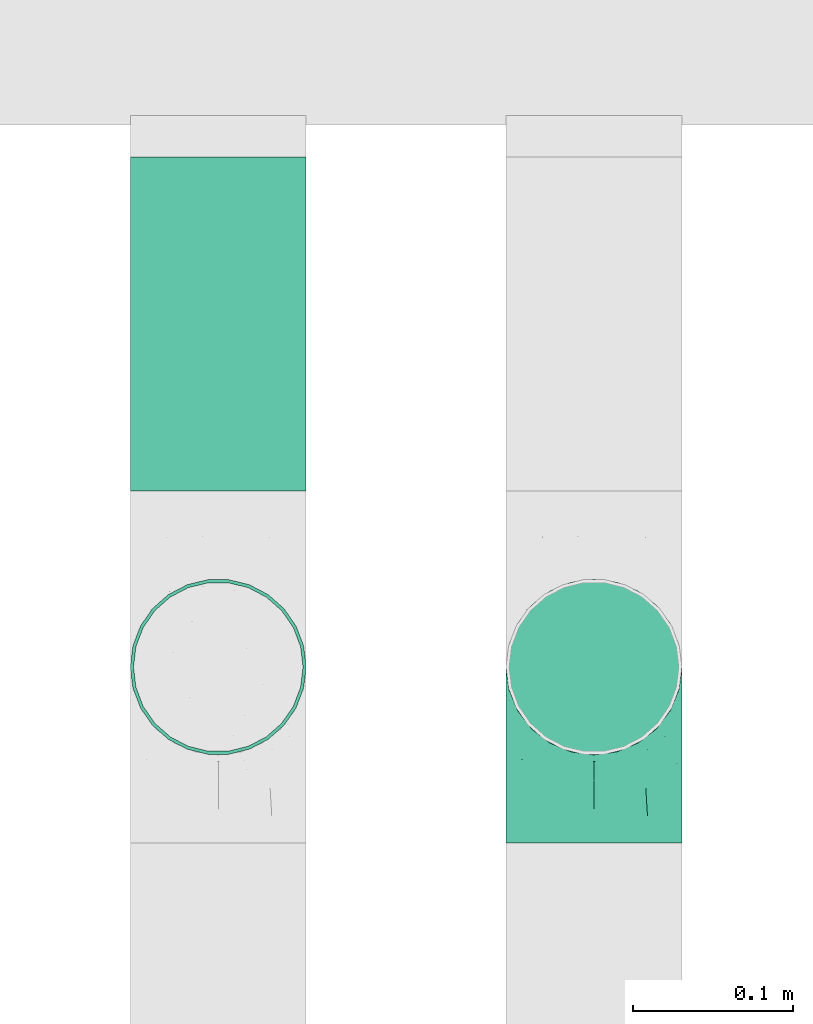
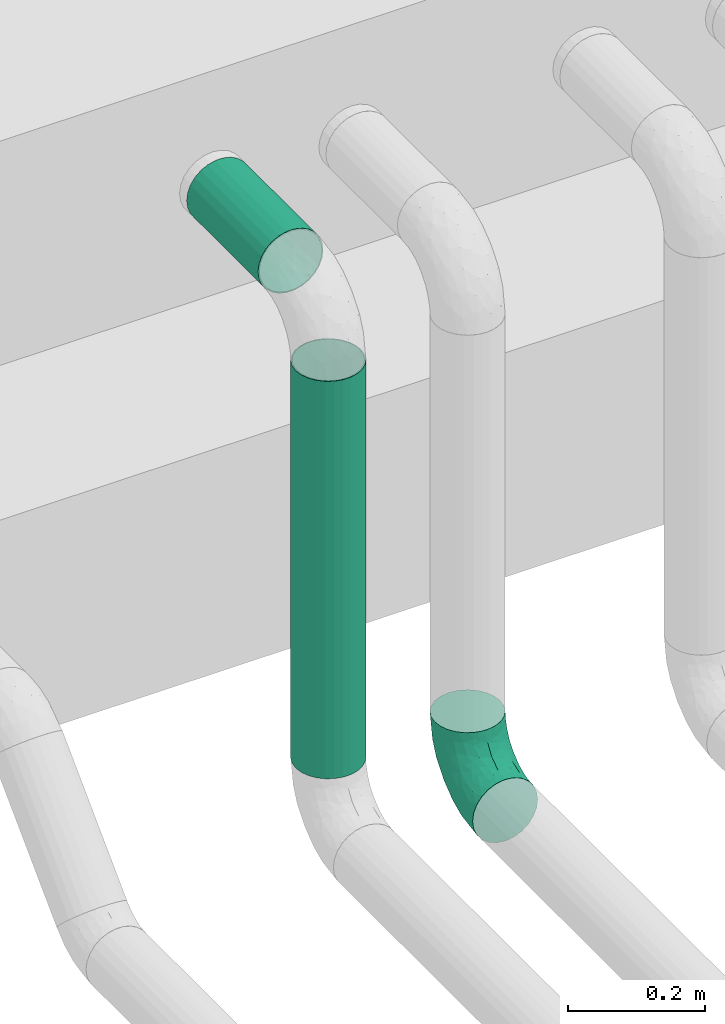
# One storey, part 9 of 91: 2 flow segments, 1 flow fitting.
"""IFC2X3 building model written with IfcOpenShell, lengths in millimetres."""

from ifc_helpers import new_model, entity, si_unit, converted_unit, derived_unit, direction, frame, origin_with_axes, origin_2d_with_axis, place, context, subcontext, project, spatial, hollow_circle, extrude, open_shell, surface_model, source, transform, mapped, material, layer, layer_set, layer_usage, type_object, element, save


model = new_model("IFC2X3")

# Units and contexts
model_context = context("Model", 3, precision=1e-05, world=origin_with_axes(), true_north=direction((0.0, 1.0)))
body_context = subcontext(model_context, "Body", "Model", "MODEL_VIEW")
ifc_project = project(units=[si_unit("AREAUNIT", "SQUARE_METRE"), si_unit("VOLUMEUNIT", "CUBIC_METRE", prefix="DECI"), si_unit("TIMEUNIT", "SECOND"), si_unit("THERMODYNAMICTEMPERATUREUNIT", "DEGREE_CELSIUS"), si_unit("PRESSUREUNIT", "PASCAL"), si_unit("MASSUNIT", "GRAM", prefix="KILO"), si_unit("LENGTHUNIT", "METRE", prefix="MILLI"), si_unit("POWERUNIT", "WATT"), si_unit("ELECTRICCURRENTUNIT", "AMPERE"), si_unit("ELECTRICVOLTAGEUNIT", "VOLT"), derived_unit("VOLUMETRICFLOWRATEUNIT", [(si_unit("VOLUMEUNIT", "CUBIC_METRE", prefix="DECI"), 1), (si_unit("TIMEUNIT", "SECOND"), -1)]), derived_unit("LINEARVELOCITYUNIT", [(si_unit("LENGTHUNIT", "METRE"), 1), (si_unit("TIMEUNIT", "SECOND"), -1)]), derived_unit("MASSDENSITYUNIT", [(si_unit("MASSUNIT", "GRAM", prefix="KILO"), 1), (si_unit("VOLUMEUNIT", "CUBIC_METRE"), -1)]), converted_unit("PLANEANGLEUNIT", "DEGREE", entity("IfcRatioMeasure", 0.01745), si_unit("PLANEANGLEUNIT", "RADIAN"), dimensions=[0, 0, 0, 0, 0, 0, 0])], contexts=[model_context])

# Site, building, storey
site_placement = place(None, origin_with_axes())
site = spatial("IfcSite", under=ifc_project, at=site_placement, CompositionType="ELEMENT")
building_placement = place(site_placement, origin_with_axes())
building = spatial("IfcBuilding", under=site, at=building_placement, Name="mc-building", CompositionType="ELEMENT")
storey_placement = place(building_placement, frame((0.0, 0.0, 8700.0), z_axis=(0.0, 0.0, 1.0), x_axis=(1.0, 0.0, 0.0)))
storey = spatial("IfcBuildingStorey", under=building, at=storey_placement, CompositionType="ELEMENT", Elevation=8700.0)

# Flow segments
ifc_material = material(Name="FZ1")
ifc_layer = layer(ifc_material, 0.0)
ifc_layer_set = layer_set([ifc_layer], Name="FZ1")
ifc_layer_usage = layer_usage(ifc_layer_set, "AXIS1", "POSITIVE", 0.0)
duct_segment_type = type_object("IfcDuctSegmentType", PredefinedType="RIGIDSEGMENT")
shared_shape_1 = source(origin_with_axes(), body_context, "Body", "SweptSolid", [
    extrude(hollow_circle(Radius=55.0, WallThickness=2.0, at=origin_2d_with_axis()), frame((0.0, 0.0, 0.0), z_axis=(1.0, 0.0, 0.0), x_axis=(0.0, 1.0, 0.0)), (0.0, 0.0, 1.0), 709.0),
])
flow_segment_1_placement = place(storey_placement, frame((8357.82156, 2612.35324, 1234.0), z_axis=(0.0, 1.0, 0.0), x_axis=(0.0, 0.0, -1.0)))
element("IfcFlowSegment", 1, at=flow_segment_1_placement, inside=storey, type_object=duct_segment_type, material=ifc_layer_usage, context=body_context, shape_type="MappedRepresentation", body=[
    mapped(shared_shape_1, transform((0.0, 0.0, 0.0), scale=1.0)),
])
shared_shape_2 = source(origin_with_axes(), body_context, "Body", "SweptSolid", [
    extrude(hollow_circle(Radius=55.0, WallThickness=2.0, at=origin_2d_with_axis()), frame((0.0, 0.0, 0.0), z_axis=(1.0, 0.0, 0.0), x_axis=(0.0, 1.0, 0.0)), (0.0, 0.0, 1.0), 208.9),
])
flow_segment_2_placement = place(storey_placement, frame((8357.82156, 2931.20513, 1344.0), z_axis=(0.0, 0.0, 1.0), x_axis=(0.0, -1.0, 0.0)))
element("IfcFlowSegment", 2, at=flow_segment_2_placement, inside=storey, type_object=duct_segment_type, material=ifc_layer_usage, context=body_context, shape_type="MappedRepresentation", body=[
    mapped(shared_shape_2, transform((0.0, 0.0, 0.0), scale=1.0, scale2=1.0, scale3=1.0, uniform=False)),
])

# Flow fitting
duct_fitting_type = type_object("IfcDuctFittingType", Name="BU", PredefinedType="BEND")
shared_shape_3 = source(origin_with_axes(), body_context, "Body", "SurfaceModel", [
    surface_model("IfcShellBasedSurfaceModel", [(-110.0, 0.0, -55.0), (-110.0, -14.23505, -53.12592), (-110.0, 14.23505, -53.12592), (-110.0, 53.12592, 14.23505), (-110.0, 27.5, -47.63139), (-110.0, 38.89087, -38.89087), (-110.0, -55.0, 0.0), (-110.0, -53.12592, 14.23505), (-110.0, -38.89087, -38.89087), (-110.0, -27.5, -47.63139), (-110.0, -53.12592, -14.23505), (-110.0, -47.63139, -27.5), (-110.0, -14.23505, 53.12592), (-110.0, 14.23505, 53.12592), (-110.0, 27.5, 47.63139), (-110.0, -47.63139, 27.5), (-110.0, -38.89087, 38.89087), (-110.0, -27.5, 47.63139), (-110.0, 0.0, 55.0), (-110.0, 55.0, 0.0), (-110.0, 53.12592, -14.23505), (-110.0, 47.63139, -27.5), (-110.0, 47.63139, 27.5), (-110.0, 38.89087, 38.89087), (-14.23505, 110.0, -53.12592), (-55.0, 110.0, 0.0), (0.0, 110.0, -55.0), (-27.5, 110.0, -47.63139), (-38.89087, 110.0, -38.89087), (-47.63139, 110.0, -27.5), (38.89087, 110.0, -38.89087), (53.12592, 110.0, 14.23505), (27.5, 110.0, -47.63139), (14.23505, 110.0, -53.12592), (47.63139, 110.0, -27.5), (53.12592, 110.0, -14.23505), (55.0, 110.0, 0.0), (-53.12592, 110.0, -14.23505), (-53.12592, 110.0, 14.23505), (-47.63139, 110.0, 27.5), (-38.89087, 110.0, 38.89087), (-27.5, 110.0, 47.63139), (0.0, 110.0, 55.0), (-14.23505, 110.0, 53.12592), (38.89087, 110.0, 38.89087), (47.63139, 110.0, 27.5), (27.5, 110.0, 47.63139), (14.23505, 110.0, 53.12592), (-64.21732, 48.68956, 43.63444), (-76.6405, 38.18013, 45.55988), (-60.44912, 32.56953, 51.94617), (-76.00813, 5.38378, 55.0), (-90.15553, 11.94394, 54.09138), (-78.5998, 26.77405, 50.81338), (-70.18771, 18.55163, 54.03432), (-75.55424, 54.2118, 32.41257), (-93.27622, 45.77614, 33.48188), (-96.12334, 22.13664, 50.81337), (-21.00813, 45.34362, 55.0), (-18.36258, 70.48427, 54.04484), (-32.04182, 59.64019, 52.24446), (-63.88653, 74.77858, 17.99134), (-74.66383, 63.08407, 19.92123), (-63.60674, 66.07878, 29.97482), (-99.597, 52.72185, 18.52927), (-93.11138, 56.59448, 10.50359), (-98.21577, 57.34403, 0.0), (-53.42855, 92.60092, 21.04759), (-88.54852, 54.8376, 21.04759), (-11.86161, 90.23965, 54.10313), (-5.38378, 76.00813, 55.0), (-57.34403, 98.21577, 0.0), (-56.64619, 93.12774, 10.22088), (-45.34362, 21.00813, 55.0), (-44.60838, 44.60838, 52.13415), (-92.68484, 35.46673, 43.63443), (-22.25266, 95.40765, 50.81337), (-35.97783, 90.61597, 43.63443), (-43.70931, 69.58671, 44.47149), (-27.23711, 77.39884, 50.81337), (-57.2828, 79.3123, 24.9774), (-58.67786, 84.31125, 16.04456), (-82.93277, 60.36161, 12.91784), (-49.88337, 54.51816, 47.224), (-74.57753, 66.83759, 9.55742), (-45.35812, 94.97281, 33.48188), (-59.18663, 88.95241, 0.0), (-51.517, 78.6292, 33.48188), (-65.14788, 80.03077, 0.0), (-56.45322, 62.06476, 39.63545), (-88.95241, 59.18663, 0.0), (-71.10913, 71.10913, 0.0), (-80.03077, 65.14788, 0.0), (-94.9309, 45.36788, -33.48188), (-93.11358, 56.60141, -10.46614), (-99.64997, 52.79499, -18.30015), (-90.20425, 36.08686, -43.63443), (-79.99933, 46.56772, -37.92748), (-76.00813, 5.38378, -55.0), (-72.75364, 19.68651, -53.60527), (-45.34362, 21.00813, -55.0), (-21.91957, 65.12078, -53.85897), (-5.38378, 76.00813, -55.0), (-21.00813, 45.34362, -55.0), (-35.41876, 92.89265, -43.63443), (-91.10309, 11.02766, -54.21832), (-45.77614, 93.27622, -33.48188), (-90.50474, 23.21022, -50.81337), (-70.92854, 33.31794, -49.51754), (-78.52933, 63.35627, -11.73997), (-24.91508, 84.05606, -50.81337), (-88.78941, 54.74452, -21.04759), (-69.59921, 57.34866, -33.48187), (-73.36422, 62.46673, -22.94182), (-63.49062, 67.59111, -28.46929), (-56.59448, 93.11138, -10.50359), (-54.8376, 88.54852, -21.04759), (-54.10679, 75.85581, -32.31867), (-57.75956, 31.09612, -52.80882), (-52.72185, 99.597, -18.52927), (-12.62913, 89.46304, -53.99097), (-34.46825, 66.46123, -50.04329), (-43.9837, 43.9837, -52.42279), (-65.78527, 72.58348, -17.68796), (-70.34468, 43.65295, -44.21951), (-57.47001, 51.99467, -44.91465), (-60.72547, 82.29174, -12.88567), (-42.34915, 74.24548, -43.63444), (-57.25194, 63.5016, -38.08211), (-80.95344, 53.56991, -29.32027), (-52.32891, 4.55257, -54.0482), (32.52942, 47.13398, -30.48571), (14.88266, 20.92917, -33.7947), (14.95561, 36.05775, -42.26543), (30.24048, 70.09027, -41.7461), (19.3559, 65.35825, -48.00507), (-70.35075, -46.44478, -19.5952), (-47.13398, -32.52942, -30.48571), (-28.49299, -30.5778, -16.4009), (-4.55257, 52.32891, -54.0482), (-22.4954, 22.4954, -53.25347), (-75.47368, -11.22546, -52.60718), (-81.32209, -51.5606, -9.98467), (-80.81763, -41.84862, -32.14655), (-70.09027, -30.24048, -41.7461), (-36.05774, -14.95561, -42.26543), (-9.15831, -10.852, -27.8997), (-65.35825, -19.3559, -48.00507), (11.22546, 75.47368, -52.60718), (3.94376, 43.9333, -50.53315), (-13.39742, 13.39743, -48.13058), (-43.9333, -3.94376, -50.53315), (49.37776, 67.29486, 0.0), (41.8609, 47.82256, -9.92641), (50.20582, 74.51695, -9.9731), (18.93131, 11.7156, -17.56239), (-27.5, -32.89419, 0.0), (-1.23348, -12.25375, -12.18106), (41.84862, 80.81763, -32.14655), (35.70604, 41.31408, -20.38235), (46.44478, 70.35075, -19.5952), (32.89419, 27.5, 0.0), (6.67262, -6.67262, 0.0), (-67.29486, -49.37776, 0.0), (-50.36265, -42.95545, -9.51562), (-5.47251, 5.47251, -39.92906), (-70.35075, -46.44478, 19.5952), (-74.51695, -50.20582, 9.9731), (-41.31407, -35.70604, 20.38235), (-47.13398, -32.52942, 30.48571), (-80.81763, -41.84862, 32.14655), (-4.55257, 52.32891, 54.0482), (11.22546, 75.47368, 52.60718), (-43.9333, -3.94376, 50.53315), (-65.35825, -19.3559, 48.00507), (-36.05774, -14.95561, 42.26543), (-70.09027, -30.24048, 41.7461), (-11.7156, -18.93131, 17.56239), (30.5778, 28.49299, 16.4009), (12.25375, 1.23348, 12.18106), (51.5606, 81.32209, 9.98467), (42.95545, 50.36265, 9.51562), (-75.47368, -11.22546, 52.60718), (-52.32891, 4.55257, 54.0482), (3.94376, 43.9333, 50.53315), (-22.4954, 22.4954, 53.25347), (-13.39742, 13.39743, 48.13058), (10.852, 9.15831, 27.8997), (-20.92916, -14.88266, 33.79469), (-47.82256, -41.8609, 9.92641), (32.52942, 47.13398, 30.48571), (46.44478, 70.35075, 19.5952), (41.84862, 80.81763, 32.14655), (30.24048, 70.09027, 41.7461), (19.3559, 65.35825, 48.00507), (14.95561, 36.05775, 42.26543), (-5.47251, 5.47251, 39.92906)], [open_shell([[[0, 1, 2]], [[2, 3, 4]], [[4, 3, 5]], [[2, 6, 7]], [[8, 6, 9]], [[1, 9, 6]], [[10, 6, 11]], [[8, 11, 6]], [[6, 2, 1]], [[12, 13, 14]], [[15, 2, 7]], [[16, 17, 2]], [[2, 17, 12]], [[12, 18, 13]], [[19, 20, 3]], [[5, 3, 21]], [[20, 21, 3]], [[22, 3, 2]], [[23, 22, 2]], [[12, 14, 2]], [[2, 14, 23]], [[15, 16, 2]], [[24, 25, 26]], [[27, 25, 24]], [[25, 28, 29]], [[28, 25, 27]], [[30, 26, 31]], [[26, 30, 32]], [[32, 33, 26]], [[34, 31, 35]], [[31, 34, 30]], [[35, 31, 36]], [[29, 37, 25]], [[38, 39, 26]], [[39, 40, 26]], [[41, 42, 40]], [[42, 26, 40]], [[42, 41, 43]], [[26, 44, 45]], [[31, 26, 45]], [[26, 46, 44]], [[47, 46, 26]], [[42, 47, 26]], [[25, 38, 26]], [[48, 49, 50]], [[18, 51, 52]], [[53, 54, 50]], [[55, 56, 49]], [[56, 22, 23]], [[13, 57, 14]], [[58, 59, 60]], [[61, 62, 63]], [[3, 64, 65]], [[53, 52, 54]], [[3, 65, 66]], [[67, 39, 38]], [[56, 68, 64]], [[65, 64, 68]], [[69, 59, 70]], [[38, 71, 72]], [[73, 58, 74]], [[75, 49, 56]], [[76, 69, 43]], [[53, 57, 52]], [[77, 78, 79]], [[41, 76, 43]], [[43, 69, 42]], [[55, 68, 56]], [[23, 14, 75]], [[76, 77, 79]], [[80, 67, 81]], [[62, 82, 68]], [[60, 78, 83]], [[62, 84, 82]], [[85, 77, 40]], [[81, 67, 72]], [[86, 72, 71]], [[87, 85, 67]], [[61, 81, 88]], [[77, 41, 40]], [[78, 77, 87]], [[23, 75, 56]], [[83, 89, 48]], [[85, 40, 39]], [[62, 68, 55]], [[89, 87, 63]], [[83, 48, 50]], [[57, 75, 14]], [[49, 75, 53]], [[67, 85, 39]], [[87, 77, 85]], [[63, 62, 55]], [[89, 55, 48]], [[80, 63, 87]], [[66, 65, 90]], [[66, 19, 3]], [[84, 91, 92]], [[92, 90, 82]], [[65, 82, 90]], [[61, 84, 62]], [[92, 82, 84]], [[68, 82, 65]], [[3, 22, 64]], [[56, 64, 22]], [[38, 25, 71]], [[81, 72, 86]], [[38, 72, 67]], [[91, 61, 88]], [[80, 81, 61]], [[63, 80, 61]], [[67, 80, 87]], [[77, 76, 41]], [[79, 59, 69]], [[79, 69, 76]], [[42, 69, 70]], [[60, 59, 79]], [[58, 70, 59]], [[78, 60, 79]], [[58, 60, 74]], [[52, 57, 13]], [[75, 57, 53]], [[18, 52, 13]], [[52, 51, 54]], [[51, 73, 54]], [[50, 73, 74]], [[73, 50, 54]], [[50, 74, 83]], [[60, 83, 74]], [[89, 83, 78]], [[87, 89, 78]], [[55, 89, 63]], [[50, 49, 53]], [[55, 49, 48]], [[81, 86, 88]], [[91, 84, 61]], [[5, 21, 93]], [[90, 94, 66]], [[20, 94, 95]], [[96, 93, 97]], [[98, 99, 100]], [[96, 4, 5]], [[101, 102, 103]], [[28, 27, 104]], [[2, 105, 0]], [[104, 106, 28]], [[99, 105, 107]], [[108, 107, 96]], [[90, 109, 94]], [[107, 2, 4]], [[20, 66, 94]], [[27, 24, 110]], [[109, 111, 94]], [[112, 113, 114]], [[37, 115, 71]], [[116, 106, 117]], [[99, 118, 100]], [[116, 115, 119]], [[37, 119, 115]], [[24, 120, 110]], [[121, 110, 101]], [[119, 106, 116]], [[101, 110, 120]], [[122, 103, 100]], [[117, 123, 116]], [[124, 125, 108]], [[115, 116, 126]], [[106, 29, 28]], [[26, 102, 120]], [[127, 104, 110]], [[97, 124, 96]], [[125, 122, 118]], [[128, 127, 125]], [[96, 5, 93]], [[115, 126, 86]], [[117, 106, 127]], [[111, 113, 129]], [[95, 93, 21]], [[97, 129, 112]], [[110, 104, 27]], [[106, 104, 127]], [[96, 107, 4]], [[99, 107, 108]], [[99, 108, 118]], [[105, 99, 98]], [[112, 114, 128]], [[121, 125, 127]], [[20, 19, 66]], [[109, 90, 92]], [[94, 111, 95]], [[91, 123, 109]], [[129, 113, 112]], [[93, 95, 111]], [[21, 20, 95]], [[71, 115, 86]], [[71, 25, 37]], [[123, 91, 88]], [[126, 116, 123]], [[123, 88, 126]], [[86, 126, 88]], [[37, 29, 119]], [[106, 119, 29]], [[129, 93, 111]], [[124, 112, 125]], [[0, 105, 98]], [[107, 105, 2]], [[125, 118, 108]], [[100, 118, 122]], [[93, 129, 97]], [[113, 111, 109]], [[109, 123, 113]], [[114, 123, 117]], [[123, 114, 113]], [[128, 114, 117]], [[127, 128, 117]], [[112, 128, 125]], [[103, 122, 101]], [[110, 121, 127]], [[101, 122, 121]], [[125, 121, 122]], [[26, 120, 24]], [[101, 120, 102]], [[96, 124, 108]], [[92, 91, 109]], [[112, 124, 97]], [[100, 130, 98]], [[131, 132, 133]], [[32, 134, 135]], [[136, 137, 138]], [[139, 140, 103]], [[98, 141, 0]], [[142, 10, 136]], [[143, 144, 137]], [[6, 10, 142]], [[137, 145, 146]], [[144, 147, 145]], [[143, 136, 11]], [[11, 136, 10]], [[8, 143, 11]], [[148, 149, 139]], [[8, 9, 144]], [[9, 1, 147]], [[130, 141, 98]], [[103, 140, 100]], [[148, 135, 149]], [[150, 151, 140]], [[152, 153, 154]], [[130, 140, 151]], [[148, 26, 33]], [[147, 1, 141]], [[155, 146, 132]], [[156, 138, 157]], [[134, 30, 158]], [[150, 140, 149]], [[158, 30, 34]], [[30, 134, 32]], [[153, 159, 160]], [[131, 160, 159]], [[144, 145, 137]], [[36, 152, 154]], [[146, 138, 137]], [[155, 161, 162]], [[158, 160, 131]], [[133, 149, 135]], [[156, 163, 164]], [[163, 142, 164]], [[139, 103, 102]], [[153, 152, 161]], [[34, 35, 160]], [[162, 157, 155]], [[132, 165, 133]], [[157, 146, 155]], [[140, 130, 100]], [[141, 130, 151]], [[141, 151, 147]], [[141, 1, 0]], [[102, 26, 148]], [[140, 139, 149]], [[102, 148, 139]], [[135, 33, 32]], [[151, 150, 145]], [[9, 147, 144]], [[151, 145, 147]], [[145, 165, 146]], [[135, 148, 33]], [[133, 135, 134]], [[131, 133, 134]], [[133, 165, 150]], [[133, 150, 149]], [[145, 150, 165]], [[132, 131, 159]], [[146, 165, 132]], [[160, 158, 34]], [[134, 158, 131]], [[144, 143, 8]], [[136, 143, 137]], [[155, 153, 161]], [[154, 153, 160]], [[153, 155, 159]], [[132, 159, 155]], [[160, 35, 154]], [[36, 154, 35]], [[164, 136, 138]], [[6, 142, 163]], [[136, 164, 142]], [[156, 164, 138]], [[156, 157, 162]], [[146, 157, 138]], [[15, 7, 166]], [[6, 163, 167]], [[168, 169, 166]], [[166, 169, 170]], [[171, 172, 70]], [[173, 174, 175]], [[17, 176, 174]], [[177, 156, 162]], [[176, 16, 170]], [[170, 16, 15]], [[161, 178, 179]], [[152, 180, 181]], [[182, 173, 183]], [[18, 12, 182]], [[184, 185, 186]], [[183, 185, 73]], [[183, 73, 51]], [[177, 187, 188]], [[189, 168, 166]], [[187, 178, 190]], [[16, 176, 17]], [[161, 152, 181]], [[45, 191, 31]], [[45, 44, 192]], [[192, 191, 45]], [[180, 36, 31]], [[193, 194, 195]], [[46, 47, 194]], [[193, 195, 190]], [[193, 44, 46]], [[172, 42, 70]], [[185, 58, 73]], [[189, 163, 156]], [[163, 189, 167]], [[70, 58, 171]], [[184, 171, 185]], [[169, 188, 175]], [[180, 31, 191]], [[192, 193, 190]], [[191, 190, 178]], [[182, 174, 173]], [[194, 47, 172]], [[190, 195, 187]], [[186, 185, 173]], [[162, 179, 177]], [[188, 196, 175]], [[179, 187, 177]], [[185, 171, 58]], [[172, 171, 184]], [[172, 184, 194]], [[172, 47, 42]], [[51, 18, 182]], [[185, 183, 173]], [[51, 182, 183]], [[174, 12, 17]], [[184, 186, 195]], [[46, 194, 193]], [[184, 195, 194]], [[195, 196, 187]], [[174, 182, 12]], [[175, 174, 176]], [[169, 175, 176]], [[175, 196, 186]], [[175, 186, 173]], [[195, 186, 196]], [[188, 169, 168]], [[187, 196, 188]], [[166, 170, 15]], [[176, 170, 169]], [[193, 192, 44]], [[191, 192, 190]], [[177, 189, 156]], [[167, 189, 166]], [[189, 177, 168]], [[188, 168, 177]], [[166, 7, 167]], [[6, 167, 7]], [[181, 191, 178]], [[36, 180, 152]], [[191, 181, 180]], [[161, 181, 178]], [[161, 179, 162]], [[187, 179, 178]]])]),
])
flow_fitting_placement = place(storey_placement, frame((8592.78509, 2612.35324, 415.0), z_axis=(1.0, 0.0, 0.0), x_axis=(0.0, 1.0, 0.0)))
element("IfcFlowFitting", 3, at=flow_fitting_placement, inside=storey, type_object=duct_fitting_type, Name="BU", context=body_context, shape_type="MappedRepresentation", body=[
    mapped(shared_shape_3, transform((0.0, 0.0, 0.0), scale=1.0)),
])

save(model, "model.ifc")
